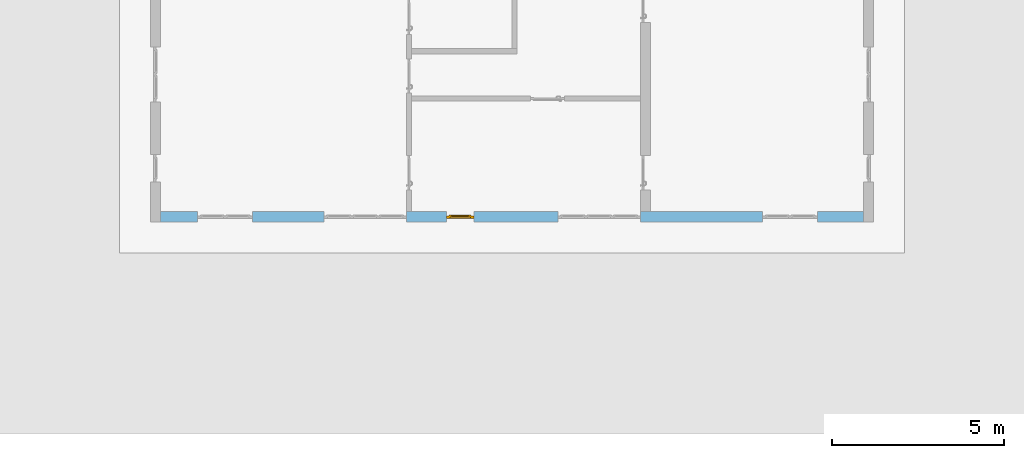
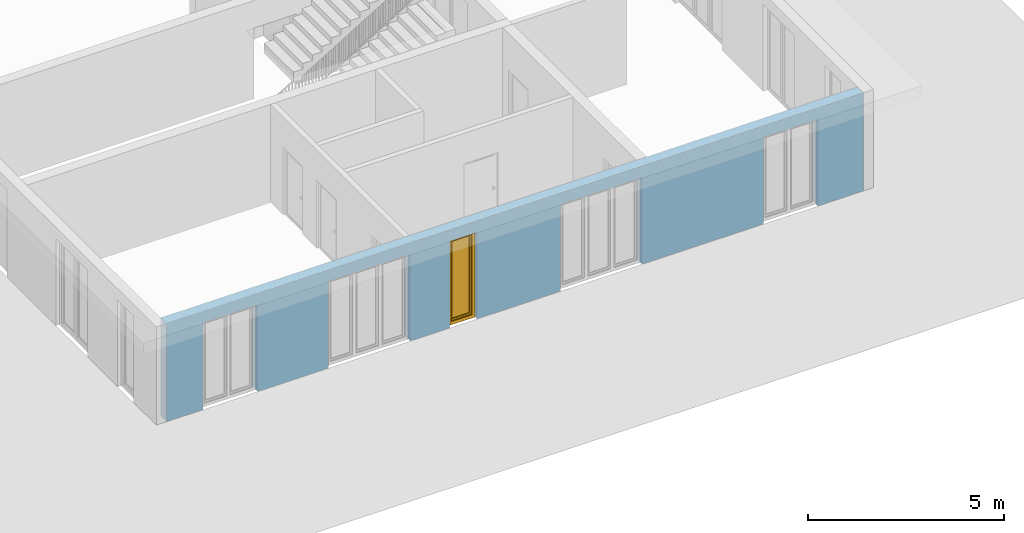
# One storey, part 6 of 23: 1 window, 5 openings, plus 1 element that does not belong to this part.
"""IFC4 building model written with IfcOpenShell, lengths in metres."""

from ifc_helpers import new_model, entity, si_unit, converted_unit, derived_unit, direction, frame, origin_with_axes, place, context, subcontext, project, spatial, polygons, source, transform, mapped, material, type_object, element, fill, save


model = new_model("IFC4")

# Units and contexts
model_context = context("Model", 3, precision=1e-05, world=origin_with_axes(), true_north=direction((0.0, 1.0)))
body_context = subcontext(model_context, "Body", "Model", "MODEL_VIEW")
ifc_project = project(units=[si_unit("LENGTHUNIT", "METRE"), si_unit("AREAUNIT", "SQUARE_METRE"), si_unit("VOLUMEUNIT", "CUBIC_METRE"), converted_unit("PLANEANGLEUNIT", "DEGREE", entity("IfcPlaneAngleMeasure", 0.0174532925199), si_unit("PLANEANGLEUNIT", "RADIAN"), dimensions=[0, 0, 0, 0, 0, 0, 0]), converted_unit("TIMEUNIT", "Year", entity("IfcTimeMeasure", 31556926.0), si_unit("TIMEUNIT", "SECOND"), dimensions=[0, 0, 1, 0, 0, 0, 0]), si_unit("MASSUNIT", "GRAM", prefix="KILO"), si_unit("THERMODYNAMICTEMPERATUREUNIT", "DEGREE_CELSIUS"), si_unit("LUMINOUSINTENSITYUNIT", "LUMEN"), si_unit("ENERGYUNIT", "JOULE", prefix="MEGA"), derived_unit("THERMALCONDUCTANCEUNIT", [(si_unit("POWERUNIT", "WATT"), 1), (si_unit("LENGTHUNIT", "METRE"), -1), (si_unit("THERMODYNAMICTEMPERATUREUNIT", "KELVIN"), -1)]), derived_unit("SPECIFICHEATCAPACITYUNIT", [(si_unit("ENERGYUNIT", "JOULE"), 1), (si_unit("MASSUNIT", "GRAM", prefix="KILO"), -1), (si_unit("THERMODYNAMICTEMPERATUREUNIT", "KELVIN"), -1)]), derived_unit("MASSDENSITYUNIT", [(si_unit("MASSUNIT", "GRAM", prefix="KILO"), 1), (si_unit("VOLUMEUNIT", "CUBIC_METRE"), -1)])], contexts=[model_context])

# Site, building, storey
site_placement = place(None, origin_with_axes())
site = spatial("IfcSite", under=ifc_project, at=site_placement, CompositionType="ELEMENT")
building_placement = place(site_placement, origin_with_axes())
building = spatial("IfcBuilding", under=site, at=building_placement, CompositionType="ELEMENT")
storey_placement = place(building_placement, origin_with_axes())
storey = spatial("IfcBuildingStorey", under=building, at=storey_placement, Name="0. Geschoss", CompositionType="ELEMENT", Elevation=0.0)

# Wall, openings, window
ifc_material = material()
wall_type = type_object("IfcWallType", Name="300", PredefinedType="NOTDEFINED")
wall_placement = place(storey_placement, frame((9.3378006196, -9.92881223104, 0.0), z_axis=(0.0, 0.0, 1.0), x_axis=(-1.0, 0.0, 0.0)))
wall = element("IfcWall", 1, at=wall_placement, inside=storey, type_object=wall_type, material=ifc_material, Name="Wand-001", PredefinedType="NOTDEFINED", context=body_context, shape_type="Tessellation", body=[
    polygons([(12.4515538751, -0.3, 2.7), (12.4515538751, -0.3, 0.0), (13.62, -0.3, 0.0), (13.62, -0.3, 2.7), (16.02, -0.3, 2.7), (16.02, -0.3, 0.0), (18.0998837323, -0.3, 0.0), (18.0998837323, -0.3, 2.7), (19.6998837323, -0.3, 2.7), (19.6998837323, -0.3, 0.0), (20.78, -0.3, 0.0), (20.78, -0.3, 3.05), (0.3, -0.3, 3.05), (0.3, -0.3, 0.0), (1.6378225413, -0.3, 0.0), (1.6378225413, -0.3, 2.7), (3.2378225413, -0.3, 2.7), (3.2378225413, -0.3, 0.0), (6.80048177301, -0.3, 0.0), (6.80048177301, -0.3, 2.7), (9.20048177301, -0.3, 2.7), (9.20048177301, -0.3, 0.0), (11.6515538751, -0.3, 0.0), (11.6515538751, -0.3, 2.7), (12.4515538751, -0.1, 0.0), (12.4515538751, 0.0, 2.7), (12.4515538751, 0.0, 0.0), (13.62, 0.0, 0.0), (13.62, 0.0, 2.7), (16.02, 0.0, 2.7), (16.02, 0.0, 0.0), (18.0998837323, 0.0, 0.0), (18.0998837323, 0.0, 2.7), (19.6998837323, 0.0, 2.7), (19.6998837323, 0.0, 0.0), (20.78, 0.0, 0.0), (20.78, 0.0, 3.05), (0.3, 0.0, 3.05), (0.3, 0.0, 0.0), (1.6378225413, 0.0, 0.0), (1.6378225413, 0.0, 2.7), (3.2378225413, 0.0, 2.7), (3.2378225413, 0.0, 0.0), (6.80048177301, 0.0, 0.0), (6.80048177301, 0.0, 2.7), (9.20048177301, 0.0, 2.7), (9.20048177301, 0.0, 0.0), (11.6515538751, -0.1, 0.0), (11.6515538751, 0.0, 0.0), (11.6515538751, 0.0, 2.7)], [[[1, 2, 3, 4, 5, 6, 7, 8, 9, 10, 11, 12, 13, 14, 15, 16, 17, 18, 19, 20, 21, 22, 23, 24]], [[25, 2, 1, 26, 27]], [[2, 25, 27, 28, 3]], [[4, 3, 28, 29]], [[5, 4, 29, 30]], [[6, 5, 30, 31]], [[6, 31, 32, 7]], [[8, 7, 32, 33]], [[9, 8, 33, 34]], [[10, 9, 34, 35]], [[10, 35, 36, 11]], [[12, 11, 36, 37]], [[13, 12, 37, 38]], [[38, 39, 14, 13]], [[39, 40, 15, 14]], [[40, 41, 16, 15]], [[41, 42, 17, 16]], [[42, 43, 18, 17]], [[43, 44, 19, 18]], [[44, 45, 20, 19]], [[45, 46, 21, 20]], [[46, 47, 22, 21]], [[48, 23, 22, 47, 49]], [[24, 23, 48, 49, 50]], [[1, 24, 50, 26]], [[28, 27, 26, 50, 49, 47, 46, 45, 44, 43, 42, 41, 40, 39, 38, 37, 36, 35, 34, 33, 32, 31, 30, 29]]], closed=True),
])
opening_1_placement = place(wall_placement, frame((18.8998837323, 0.0, 0.0), z_axis=(0.0, 0.0, 1.0), x_axis=(1.0, 0.0, 0.0)))
element("IfcOpeningElement", 2, at=opening_1_placement, cuts=wall, Name="Fenster-001", context=body_context, identifier="Reference", shape_type="Tessellation", body=[
    polygons([(-0.8, -0.1, 0.0), (-0.8, -0.1, 2.7), (-0.8, 0.001, 2.7), (-0.8, 0.001, 0.0), (-0.8, -0.301, 0.0), (-0.8, -0.301, 2.7), (0.8, -0.1, 2.7), (0.8, 0.001, 2.7), (0.8, -0.301, 2.7), (0.8, 0.001, 0.0), (0.8, -0.1, 0.0), (0.8, -0.301, 0.0)], [[[1, 2, 3, 4]], [[2, 1, 5, 6]], [[7, 8, 3, 2, 6, 9]], [[8, 10, 4, 3]], [[1, 4, 10, 11, 12, 5]], [[6, 5, 12, 9]], [[7, 11, 10, 8]], [[11, 7, 9, 12]]], closed=True),
])
opening_2_placement = place(wall_placement, frame((2.4378225413, 0.0, 0.0), z_axis=(0.0, 0.0, 1.0), x_axis=(1.0, 0.0, 0.0)))
element("IfcOpeningElement", 3, at=opening_2_placement, cuts=wall, Name="Fenster-002", context=body_context, identifier="Reference", shape_type="Tessellation", body=[
    polygons([(-0.8, -0.1, 0.0), (-0.8, -0.1, 2.7), (-0.8, 0.000999999999999, 2.7), (-0.8, 0.000999999999999, 0.0), (-0.8, -0.301, 0.0), (-0.8, -0.301, 2.7), (0.8, -0.1, 2.7), (0.8, 0.000999999999999, 2.7), (0.8, -0.301, 2.7), (0.8, 0.000999999999999, 0.0), (0.8, -0.1, 0.0), (0.8, -0.301, 0.0)], [[[1, 2, 3, 4]], [[2, 1, 5, 6]], [[7, 8, 3, 2, 6, 9]], [[8, 10, 4, 3]], [[1, 4, 10, 11, 12, 5]], [[6, 5, 12, 9]], [[7, 11, 10, 8]], [[11, 7, 9, 12]]], closed=True),
])
opening_3_placement = place(wall_placement, frame((14.82, 0.0, 0.0), z_axis=(0.0, 0.0, 1.0), x_axis=(1.0, 0.0, 0.0)))
element("IfcOpeningElement", 4, at=opening_3_placement, cuts=wall, Name="Fenster-002", context=body_context, identifier="Reference", shape_type="Tessellation", body=[
    polygons([(-1.2, -0.1, 0.0), (-1.2, -0.1, 2.7), (-1.2, 0.001, 2.7), (-1.2, 0.001, 0.0), (-1.2, -0.301, 0.0), (-1.2, -0.301, 2.7), (1.2, -0.1, 2.7), (1.2, 0.001, 2.7), (1.2, -0.301, 2.7), (1.2, 0.001, 0.0), (1.2, -0.1, 0.0), (1.2, -0.301, 0.0)], [[[1, 2, 3, 4]], [[2, 1, 5, 6]], [[7, 8, 3, 2, 6, 9]], [[8, 10, 4, 3]], [[1, 4, 10, 11, 12, 5]], [[6, 5, 12, 9]], [[7, 11, 10, 8]], [[11, 7, 9, 12]]], closed=True),
])
opening_4_placement = place(wall_placement, frame((8.00048177301, 0.0, 0.0), z_axis=(0.0, 0.0, 1.0), x_axis=(1.0, 0.0, 0.0)))
element("IfcOpeningElement", 5, at=opening_4_placement, cuts=wall, Name="Fenster-003", context=body_context, identifier="Reference", shape_type="Tessellation", body=[
    polygons([(-1.2, -0.1, 0.0), (-1.2, -0.1, 2.7), (-1.2, 0.001, 2.7), (-1.2, 0.001, 0.0), (-1.2, -0.301, 0.0), (-1.2, -0.301, 2.7), (1.2, -0.1, 2.7), (1.2, 0.001, 2.7), (1.2, -0.301, 2.7), (1.2, 0.001, 0.0), (1.2, -0.1, 0.0), (1.2, -0.301, 0.0)], [[[1, 2, 3, 4]], [[2, 1, 5, 6]], [[7, 8, 3, 2, 6, 9]], [[8, 10, 4, 3]], [[1, 4, 10, 11, 12, 5]], [[6, 5, 12, 9]], [[7, 11, 10, 8]], [[11, 7, 9, 12]]], closed=True),
])
opening_5_placement = place(wall_placement, frame((12.0515538751, 0.0, 0.0), z_axis=(0.0, 0.0, 1.0), x_axis=(1.0, 0.0, 0.0)))
opening_5 = element("IfcOpeningElement", 6, at=opening_5_placement, cuts=wall, Name="Fenster-003", context=body_context, identifier="Reference", shape_type="Tessellation", body=[
    polygons([(-0.4, -0.1, 0.0), (-0.4, -0.1, 2.7), (-0.4, 0.001, 2.7), (-0.4, 0.001, 0.0), (-0.4, -0.301, 0.0), (-0.4, -0.301, 2.7), (0.4, -0.1, 2.7), (0.4, 0.001, 2.7), (0.4, -0.301, 2.7), (0.4, 0.001, 0.0), (0.4, -0.1, 0.0), (0.4, -0.301, 0.0)], [[[1, 2, 3, 4]], [[2, 1, 5, 6]], [[7, 8, 3, 2, 6, 9]], [[8, 10, 4, 3]], [[1, 4, 10, 11, 12, 5]], [[6, 5, 12, 9]], [[7, 11, 10, 8]], [[11, 7, 9, 12]]], closed=True),
])
window_type = type_object("IfcWindowType", Name="1-26", PartitioningType="SINGLE_PANEL", PredefinedType="WINDOW")
shared_shape = source(origin_with_axes(), body_context, "Body", "Tessellation", [
    polygons([(-0.4, -0.07, 0.0), (-0.4, 0.0, 0.0), (-0.3, 0.0, 0.1), (-0.3, -0.07, 0.1), (-0.4, -0.07, 2.7), (-0.4, 0.0, 2.7), (-0.3, 0.0, 2.6), (-0.3, -0.07, 2.6)], [[[1, 2, 3, 4]], [[5, 6, 2, 1]], [[2, 6, 7, 3]], [[4, 3, 7, 8]], [[1, 4, 8, 5]], [[8, 7, 6, 5]]], closed=True),
    polygons([(0.4, -0.07, 0.0), (0.4, 0.0, 0.0), (0.4, 0.0, 2.7), (0.4, -0.07, 2.7), (0.3, -0.07, 0.1), (0.3, 0.0, 0.1), (0.3, 0.0, 2.6), (0.3, -0.07, 2.6)], [[[1, 2, 3, 4]], [[5, 6, 2, 1]], [[2, 6, 7, 3]], [[4, 3, 7, 8]], [[1, 4, 8, 5]], [[8, 7, 6, 5]]], closed=True),
    polygons([(-0.4, -0.07, 0.0), (-0.4, 0.0, 0.0), (0.4, 0.0, 0.0), (0.4, -0.07, 0.0), (-0.3, -0.07, 0.1), (-0.3, 0.0, 0.1), (0.0, 0.0, 0.1), (0.3, 0.0, 0.1), (0.3, -0.07, 0.1), (0.0, -0.07, 0.1)], [[[1, 2, 3, 4]], [[5, 6, 2, 1]], [[2, 6, 7, 8, 3]], [[4, 3, 8, 9]], [[1, 4, 9, 10, 5]], [[10, 7, 6, 5]], [[9, 8, 7, 10]]], closed=True),
    polygons([(-0.4, -0.07, 2.7), (-0.4, 0.0, 2.7), (-0.3, 0.0, 2.6), (-0.3, -0.07, 2.6), (0.4, -0.07, 2.7), (0.4, 0.0, 2.7), (0.3, 0.0, 2.6), (0.0, 0.0, 2.6), (0.0, -0.07, 2.6), (0.3, -0.07, 2.6)], [[[1, 2, 3, 4]], [[5, 6, 2, 1]], [[2, 6, 7, 8, 3]], [[4, 3, 8, 9]], [[1, 4, 9, 10, 5]], [[10, 7, 6, 5]], [[9, 8, 7, 10]]], closed=True),
    polygons([(-0.32, 0.0, 0.08), (-0.32, 0.03, 0.08), (-0.25, 0.03, 0.15), (-0.25, 0.0, 0.15), (-0.32, 0.0, 2.62), (-0.32, 0.03, 2.62), (-0.25, 0.03, 2.55), (-0.25, 0.0, 2.55)], [[[1, 2, 3, 4]], [[5, 6, 2, 1]], [[2, 6, 7, 3]], [[4, 3, 7, 8]], [[1, 4, 8, 5]], [[8, 7, 6, 5]]], closed=True),
    polygons([(0.32, 0.0, 0.08), (0.25, 0.0, 0.15), (0.25, 0.03, 0.15), (0.32, 0.03, 0.08), (0.32, 0.0, 2.62), (0.25, 0.0, 2.55), (0.25, 0.03, 2.55), (0.32, 0.03, 2.62)], [[[1, 2, 3, 4]], [[1, 5, 6, 2]], [[2, 6, 7, 3]], [[4, 3, 7, 8]], [[5, 1, 4, 8]], [[6, 5, 8, 7]]], closed=True),
    polygons([(-0.32, 0.0, 0.08), (-0.32, 0.03, 0.08), (0.32, 0.03, 0.08), (0.32, 0.0, 0.08), (-0.25, 0.0, 0.15), (-0.25, 0.03, 0.15), (0.25, 0.03, 0.15), (0.25, 0.0, 0.15)], [[[1, 2, 3, 4]], [[5, 6, 2, 1]], [[2, 6, 7, 3]], [[4, 3, 7, 8]], [[1, 4, 8, 5]], [[8, 7, 6, 5]]], closed=True),
    polygons([(-0.32, 0.0, 2.62), (0.32, 0.0, 2.62), (0.32, 0.03, 2.62), (-0.32, 0.03, 2.62), (-0.25, 0.0, 2.55), (0.25, 0.0, 2.55), (0.25, 0.03, 2.55), (-0.25, 0.03, 2.55)], [[[1, 2, 3, 4]], [[1, 5, 6, 2]], [[2, 6, 7, 3]], [[4, 3, 7, 8]], [[5, 1, 4, 8]], [[6, 5, 8, 7]]], closed=True),
    polygons([(-0.3, -0.03, 0.1), (-0.3, 0.0, 0.1), (-0.25, 0.0, 0.15), (-0.25, -0.03, 0.15), (-0.3, -0.03, 2.6), (-0.3, 0.0, 2.6), (-0.25, 0.0, 2.55), (-0.25, -0.03, 2.55)], [[[1, 2, 3, 4]], [[5, 6, 2, 1]], [[2, 6, 7, 3]], [[4, 3, 7, 8]], [[1, 4, 8, 5]], [[8, 7, 6, 5]]], closed=True),
    polygons([(0.3, -0.03, 0.1), (0.25, -0.03, 0.15), (0.25, 0.0, 0.15), (0.3, 0.0, 0.1), (0.3, -0.03, 2.6), (0.25, -0.03, 2.55), (0.25, 0.0, 2.55), (0.3, 0.0, 2.6)], [[[1, 2, 3, 4]], [[1, 5, 6, 2]], [[2, 6, 7, 3]], [[4, 3, 7, 8]], [[5, 1, 4, 8]], [[6, 5, 8, 7]]], closed=True),
    polygons([(-0.3, -0.03, 0.1), (-0.3, 0.0, 0.1), (0.3, 0.0, 0.1), (0.3, -0.03, 0.1), (-0.25, -0.03, 0.15), (-0.25, 0.0, 0.15), (0.25, 0.0, 0.15), (0.25, -0.03, 0.15)], [[[1, 2, 3, 4]], [[5, 6, 2, 1]], [[2, 6, 7, 3]], [[4, 3, 7, 8]], [[1, 4, 8, 5]], [[8, 7, 6, 5]]], closed=True),
    polygons([(-0.3, -0.03, 2.6), (0.3, -0.03, 2.6), (0.3, 0.0, 2.6), (-0.3, 0.0, 2.6), (-0.25, -0.03, 2.55), (0.25, -0.03, 2.55), (0.25, 0.0, 2.55), (-0.25, 0.0, 2.55)], [[[1, 2, 3, 4]], [[1, 5, 6, 2]], [[2, 6, 7, 3]], [[4, 3, 7, 8]], [[5, 1, 4, 8]], [[6, 5, 8, 7]]], closed=True),
    polygons([(-0.25, -0.005, 0.15), (-0.25, 0.005, 0.15), (0.25, 0.005, 0.15), (0.25, -0.005, 0.15), (-0.25, -0.005, 2.55), (-0.25, 0.005, 2.55), (0.25, 0.005, 2.55), (0.25, -0.005, 2.55)], [[[1, 2, 3, 4]], [[5, 6, 2, 1]], [[2, 6, 7, 3]], [[4, 3, 7, 8]], [[1, 4, 8, 5]], [[8, 7, 6, 5]]], closed=True),
])
window_placement = place(opening_5_placement, frame((0.4, 0.0, 0.0), z_axis=(0.0, 0.0, 1.0), x_axis=(-1.0, 0.0, 0.0)))
window = element("IfcWindow", 7, at=window_placement, inside=storey, type_object=window_type, Name="Fenster-003", OverallHeight=2.7, OverallWidth=0.8, PredefinedType="WINDOW", context=body_context, shape_type="MappedRepresentation", body=[
    mapped(shared_shape, transform((0.4, 0.17, 0.0))),
])
fill(opening_5, window)

save(model, "model.ifc")
